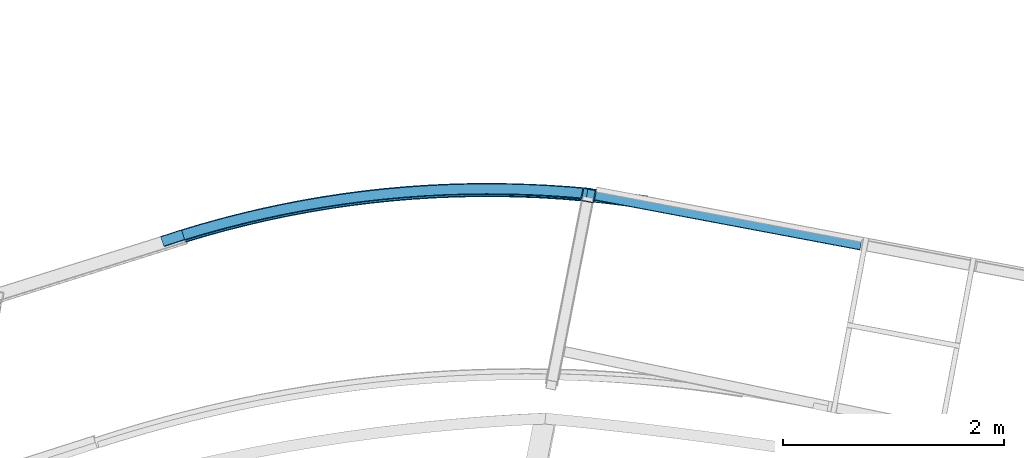
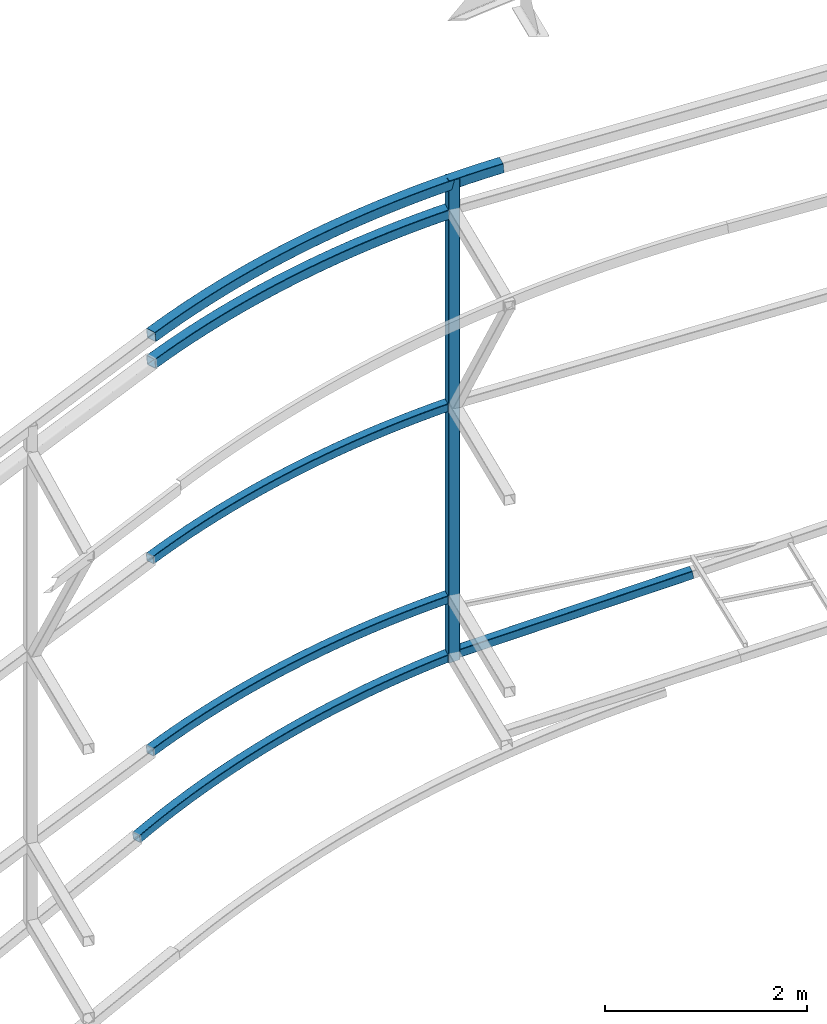
# One storey, part 125 of 215: 7 beams, 7 elements without a shape of their own.
"""IFC2X3 building model written with IfcOpenShell, lengths in millimetres."""

from ifc_helpers import new_model, entity, si_unit, frame, origin_with_axes, origin_2d_with_axis, place, context, subcontext, project, spatial, hollow_rectangle, extrude, clip, halfspace, material, type_object, element, aggregate, save


model = new_model("IFC2X3")

# Units and contexts
model_context = context("Model", 3, precision=1e-05, world=origin_with_axes())
body_context = subcontext(model_context, "Body", "Model", "MODEL_VIEW")
ifc_project = project(units=[si_unit("LENGTHUNIT", "METRE", prefix="MILLI"), si_unit("AREAUNIT", "SQUARE_METRE"), si_unit("VOLUMEUNIT", "CUBIC_METRE"), si_unit("MASSUNIT", "GRAM", prefix="KILO"), si_unit("TIMEUNIT", "SECOND"), si_unit("PLANEANGLEUNIT", "RADIAN"), si_unit("SOLIDANGLEUNIT", "STERADIAN"), si_unit("THERMODYNAMICTEMPERATUREUNIT", "DEGREE_CELSIUS"), si_unit("LUMINOUSINTENSITYUNIT", "LUMEN")], contexts=[model_context])

# Site, building, storey
site_placement = place(None, origin_with_axes())
site = spatial("IfcSite", under=ifc_project, at=site_placement, CompositionType="ELEMENT")
building_placement = place(site_placement, origin_with_axes())
building = spatial("IfcBuilding", under=site, at=building_placement, Name="Undefined", CompositionType="ELEMENT")
storey_placement = place(building_placement, origin_with_axes())
storey = spatial("IfcBuildingStorey", under=building, at=storey_placement, Name="Undefined", CompositionType="ELEMENT", Elevation=0.0)

# Assembly, beam
assembly_1_placement = place(storey_placement, origin_with_axes())
assembly_1 = element("IfcElementAssembly", 1, at=assembly_1_placement, inside=storey, Name="Steel Assembly", AssemblyPlace="NOTDEFINED", PredefinedType="RIGID_FRAME")
ifc_material = material(Name="STEEL/S275JR")
beam_type_1 = type_object("IfcBeamType", PredefinedType="NOTDEFINED")
beam_1_placement = place(assembly_1_placement, frame((57199.4715677432, 64182.9141119581, 8169.10995780599), z_axis=(0.0728264169784525, -0.997320842704967, -0.00688837399796234), x_axis=(0.992677374277519, 0.0718164840200777, 0.097128900027154)))
beam_1 = element("IfcBeam", 2, at=beam_1_placement, type_object=beam_type_1, material=ifc_material, Name="LISSE", context=body_context, shape_type="SweptSolid", body=[
    entity("IfcRevolvedAreaSolid", entity("IfcRectangleHollowProfileDef", "AREA", None, entity("IfcAxis2Placement2D", entity("IfcCartesianPoint", [0.0, 0.0]), entity("IfcDirection", [1.0, 0.0])), 120.0, 120.0, 4.0, 4.0, 8.0), entity("IfcAxis2Placement3D", entity("IfcCartesianPoint", [4215.74229059545, 1.36424205265939e-12, 4.93637430611081e-14]), entity("IfcDirection", [-0.974751729984506, -1.93674447038246e-19, -0.223291434883234]), entity("IfcDirection", [-6.93889390390723e-18, -1.0, -3.46944695195361e-18])), entity("IfcAxis1Placement", entity("IfcCartesianPoint", [0.0, 9440.0, 0.0]), entity("IfcDirection", [-1.0, 0.0, 0.0])), 0.450379724851634),
])
aggregate(assembly_1, [beam_1])

assembly_2_placement = place(storey_placement, origin_with_axes())
assembly_2 = element("IfcElementAssembly", 3, at=assembly_2_placement, inside=storey, Name="Steel Assembly", AssemblyPlace="NOTDEFINED", PredefinedType="RIGID_FRAME")
beam_type_2 = type_object("IfcBeamType", PredefinedType="NOTDEFINED")
beam_2_placement = place(assembly_2_placement, frame((60857.815872179, 64550.9421828142, 8582.9160704874), z_axis=(-0.191859508000518, -0.981422401002646, -1.00000033853845e-09), x_axis=(0.0, 0.0, -1.0)))
beam_2 = element("IfcBeam", 4, at=beam_2_placement, type_object=beam_type_2, material=ifc_material, Name="MONTANT", context=body_context, shape_type="Clipping", body=[
    clip(extrude(hollow_rectangle(XDim=120.0, YDim=120.0, WallThickness=5.0, InnerFilletRadius=5.0, OuterFilletRadius=10.0, at=origin_2d_with_axis()), frame((5834.22832578777, 0.0, 0.0), z_axis=(-1.0, 0.0, 0.0), x_axis=(-6.93889390390723e-18, -1.0, -3.46944695195361e-18)), (0.0, 0.0, 1.0), 5834.2), halfspace(frame((5812.09772795123, 77.5749632478037, -60.592861088895), z_axis=(-0.987578643100695, -0.157120914440339, 0.00120080673767988), x_axis=(0.0, -0.007642341407296, -0.999970796882496)), True)),
])
aggregate(assembly_2, [beam_2])

assembly_3_placement = place(storey_placement, origin_with_axes())
assembly_3 = element("IfcElementAssembly", 5, at=assembly_3_placement, inside=storey, Name="Steel Assembly", AssemblyPlace="NOTDEFINED", PredefinedType="RIGID_FRAME")
beam_3_placement = place(assembly_3_placement, frame((57199.8187951211, 64183.68814857, 7843.87293399419), z_axis=(-0.100909641037692, 0.994895594371629, 2.54080000099159e-05), x_axis=(0.990831917847986, 0.100495166984582, 0.0902930339861472)))
beam_3 = element("IfcBeam", 6, at=beam_3_placement, type_object=beam_type_2, material=ifc_material, Name="LISSE", context=body_context, shape_type="SweptSolid", body=[
    entity("IfcRevolvedAreaSolid", entity("IfcRectangleHollowProfileDef", "AREA", None, entity("IfcAxis2Placement2D", entity("IfcCartesianPoint", [0.0, 0.0]), entity("IfcDirection", [1.0, 0.0])), 120.0, 120.0, 5.0, 5.0, 10.0), entity("IfcAxis2Placement3D", entity("IfcCartesianPoint", [3704.163727995, -1.41564765088191e-12, -7.25811594338922e-12]), entity("IfcDirection", [-0.980564876868472, 1.33461657430745e-17, 0.1961951127116]), entity("IfcDirection", [-6.93889390390723e-18, -1.0, -3.46944695195361e-18])), entity("IfcAxis1Placement", entity("IfcCartesianPoint", [0.0, -9440.0, 0.0]), entity("IfcDirection", [1.0, 0.0, 0.0])), 0.394952204272541),
])
aggregate(assembly_3, [beam_3])

assembly_4_placement = place(storey_placement, origin_with_axes())
assembly_4 = element("IfcElementAssembly", 7, at=assembly_4_placement, inside=storey, Name="Steel Assembly", AssemblyPlace="NOTDEFINED", PredefinedType="RIGID_FRAME")
beam_type_3 = type_object("IfcBeamType", PredefinedType="NOTDEFINED")
beam_4_placement = place(assembly_4_placement, frame((60853.5302334386, 64567.3974300605, 2808.11898164963), z_axis=(0.185059002917875, 0.982727411563879, 0.0), x_axis=(0.970975106212946, -0.182845907040102, 0.154190523033816)))
beam_4 = element("IfcBeam", 8, at=beam_4_placement, type_object=beam_type_3, material=ifc_material, Name="LISSE", context=body_context, shape_type="SweptSolid", body=[
    extrude(hollow_rectangle(XDim=100.0, YDim=100.0, WallThickness=5.0, InnerFilletRadius=5.0, OuterFilletRadius=10.0, at=origin_2d_with_axis()), frame((2553.54760472388, 9.8036988540395e-13, 6.11927324869339e-14), z_axis=(-1.0, 0.0, 0.0), x_axis=(-6.93889390390723e-18, -1.0, -3.46944695195361e-18)), (0.0, 0.0, 1.0), 2553.5),
])
aggregate(assembly_4, [beam_4])

assembly_5_placement = place(storey_placement, origin_with_axes())
assembly_5 = element("IfcElementAssembly", 9, at=assembly_5_placement, inside=storey, Name="Steel Assembly", AssemblyPlace="NOTDEFINED", PredefinedType="RIGID_FRAME")
beam_5_placement = place(assembly_5_placement, frame((57191.6215555133, 64192.3188371472, 5464.07183735548), z_axis=(-0.101011390022662, 0.99488526922321, -1.29750000025531e-05), x_axis=(0.989963033801127, 0.100512927979808, 0.0993495999800417)))
beam_5 = element("IfcBeam", 10, at=beam_5_placement, type_object=beam_type_3, material=ifc_material, Name="LISSE", context=body_context, shape_type="SweptSolid", body=[
    entity("IfcRevolvedAreaSolid", entity("IfcRectangleHollowProfileDef", "AREA", None, entity("IfcAxis2Placement2D", entity("IfcCartesianPoint", [0.0, 0.0]), entity("IfcDirection", [1.0, 0.0])), 100.0, 100.0, 5.0, 5.0, 10.0), entity("IfcAxis2Placement3D", entity("IfcCartesianPoint", [3711.3503403447, -6.82121026329696e-13, -7.26883334905973e-12]), entity("IfcDirection", [-0.98053032057047, 1.99263277696104e-19, 0.196367742875381]), entity("IfcDirection", [-6.93889390390723e-18, -1.0, -3.46944695195361e-18])), entity("IfcAxis1Placement", entity("IfcCartesianPoint", [0.0, -9450.0, 0.0]), entity("IfcDirection", [1.0, 0.0, 0.0])), 0.395304313978507),
])
aggregate(assembly_5, [beam_5])

assembly_6_placement = place(storey_placement, origin_with_axes())
assembly_6 = element("IfcElementAssembly", 11, at=assembly_6_placement, inside=storey, Name="Steel Assembly", AssemblyPlace="NOTDEFINED", PredefinedType="RIGID_FRAME")
beam_6_placement = place(assembly_6_placement, frame((57191.6338889117, 64192.3226443668, 3140.01280848216), z_axis=(-0.101265083981618, 0.994859478819425, -1.30129999974115e-05), x_axis=(0.989928271492198, 0.100764445050101, 0.0994411580494428)))
beam_6 = element("IfcBeam", 12, at=beam_6_placement, type_object=beam_type_3, material=ifc_material, Name="LISSE", context=body_context, shape_type="SweptSolid", body=[
    entity("IfcRevolvedAreaSolid", entity("IfcRectangleHollowProfileDef", "AREA", None, entity("IfcAxis2Placement2D", entity("IfcCartesianPoint", [0.0, 0.0]), entity("IfcDirection", [1.0, 0.0])), 100.0, 100.0, 5.0, 5.0, 10.0), entity("IfcAxis2Placement3D", entity("IfcCartesianPoint", [3711.44271548901, 0.0, -7.3019278377007e-12]), entity("IfcDirection", [-0.980529341738675, -6.59680992728105e-19, 0.196372630449154]), entity("IfcDirection", [-6.93889390390723e-18, -1.0, -3.46944695195361e-18])), entity("IfcAxis1Placement", entity("IfcCartesianPoint", [0.0, -9450.0, 0.0]), entity("IfcDirection", [1.0, 0.0, 0.0])), 0.395314283229044),
])
aggregate(assembly_6, [beam_6])

assembly_7_placement = place(storey_placement, origin_with_axes())
assembly_7 = element("IfcElementAssembly", 13, at=assembly_7_placement, inside=storey, Name="Steel Assembly", AssemblyPlace="NOTDEFINED", PredefinedType="RIGID_FRAME")
beam_7_placement = place(assembly_7_placement, frame((57004.0716666436, 64133.8906850255, 2191.70551517329), z_axis=(-0.114438532000476, 0.993146055004124, 0.0237641710000985), x_axis=(0.981687745636382, 0.109386351959482, 0.155960879942232)))
beam_7 = element("IfcBeam", 14, at=beam_7_placement, type_object=beam_type_3, material=ifc_material, Name="LISSE", context=body_context, shape_type="SweptSolid", body=[
    entity("IfcRevolvedAreaSolid", entity("IfcRectangleHollowProfileDef", "AREA", None, entity("IfcAxis2Placement2D", entity("IfcCartesianPoint", [0.0, 0.0]), entity("IfcDirection", [1.0, 0.0])), 100.0, 100.0, 5.0, 5.0, 10.0), entity("IfcAxis2Placement3D", entity("IfcCartesianPoint", [3925.96773071082, -1.81898940354586e-12, -7.27595761418343e-12]), entity("IfcDirection", [-0.978187655131725, 0.0, 0.207723160355069]), entity("IfcDirection", [-6.93889390390723e-18, -1.0, -3.46944695195361e-18])), entity("IfcAxis1Placement", entity("IfcCartesianPoint", [0.0, -9450.0, 0.0]), entity("IfcDirection", [1.0, 0.0, 0.0])), 0.41849354368157),
])
aggregate(assembly_7, [beam_7])

save(model, "model.ifc")
